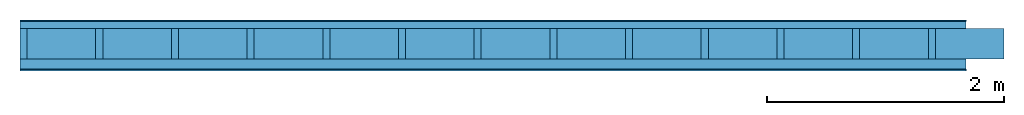
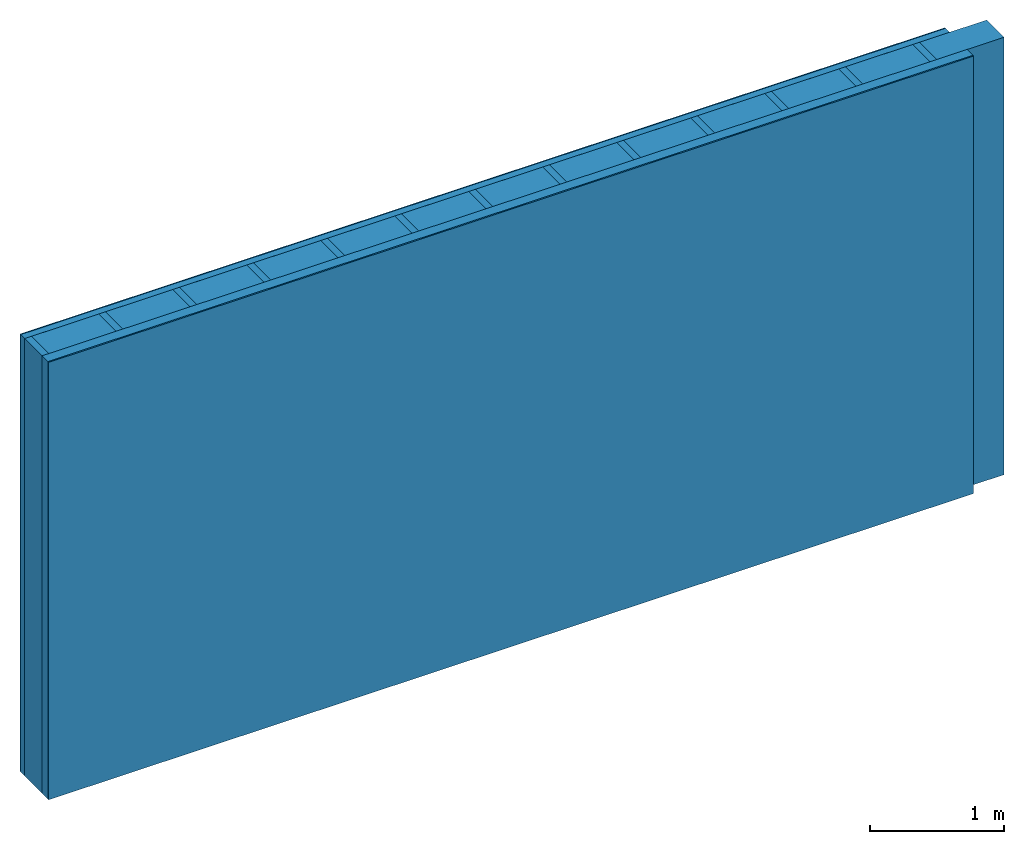
# One storey: 4 plates, 2 members, 1 element without a shape of its own.
"""IFC4 building model written with IfcOpenShell, lengths in metres."""

from ifc_helpers import new_model, si_unit, derived_unit, direction, frame, frame_2d, origin, origin_with_axes, place, context, project, spatial, rectangle, extrude, material, layer, layer_set, type_object, element, aggregate, save


model = new_model("IFC4")

# Units and contexts
plan_context = context("Plan", 3, precision=1e-05, world=origin(), true_north=direction((0.0, 1.0)))
model_context = context("Model", 3, precision=1e-05, world=origin(), true_north=direction((0.0, 1.0)))
ifc_project = project(units=[si_unit("LENGTHUNIT", "METRE"), derived_unit("SOUNDPRESSUREUNIT", [(si_unit("PRESSUREUNIT", "PASCAL", prefix="MICRO"), 0)]), si_unit("ENERGYUNIT", "JOULE", prefix="MEGA"), si_unit("MASSUNIT", "GRAM", prefix="KILO"), derived_unit("THERMALTRANSMITTANCEUNIT", [(si_unit("POWERUNIT", "WATT"), 1), (si_unit("AREAUNIT", "SQUARE_METRE"), -1), (si_unit("THERMODYNAMICTEMPERATUREUNIT", "KELVIN"), -1)]), derived_unit("AREADENSITYUNIT", [(si_unit("MASSUNIT", "GRAM", prefix="KILO"), 1), (si_unit("AREAUNIT", "SQUARE_METRE"), -1)]), derived_unit("USERDEFINED", [(si_unit("ENERGYUNIT", "JOULE", prefix="MEGA"), 1), (si_unit("AREAUNIT", "SQUARE_METRE"), -1)])], contexts=[plan_context, model_context])

# Site, building, storey
site = spatial("IfcSite", under=ifc_project)
building_placement = place(None, origin())
building = spatial("IfcBuilding", under=site, at=building_placement)
storey_placement = place(building_placement, origin())
storey = spatial("IfcBuildingStorey", under=building, at=storey_placement)

# Wall, members, plates
ifc_material_1 = material(Category="04.011")
ifc_layer_1 = layer(ifc_material_1, 0.01, Name="Surface 1")
ifc_material_2 = material(Category="10.009")
ifc_layer_2 = layer(ifc_material_2, 0.06, Name="outside 1st layer")
ifc_material_3 = material(Name="of the art")
ifc_layer_3 = layer(ifc_material_3, 0.0, Name="Bond")
ifc_layer_4 = layer(None, 0.26, Name="Support")
ifc_layer_5 = layer(ifc_material_3, 0.0, Name="Bond")
ifc_material_4 = material(Name="Solid timber panel")
ifc_layer_6 = layer(ifc_material_4, 0.087, Name="1st layer")
ifc_material_5 = material(Name="Plasterboard type A", Category="03.008")
ifc_layer_7 = layer(ifc_material_5, 0.0125, Name="Covering 1st layer")
ifc_material_6 = material(Name="joints", Category="04.017")
ifc_layer_8 = layer(ifc_material_6, 0.0, Name="Surface")
ifc_layer_set = layer_set([ifc_layer_1, ifc_layer_2, ifc_layer_3, ifc_layer_4, ifc_layer_5, ifc_layer_6, ifc_layer_7, ifc_layer_8])
wall_type = type_object("IfcWallType", Name="D0982", PredefinedType="NOTDEFINED", material=ifc_layer_set)
wall_placement = place(None, frame((0.0, 0.0, 0.0), z_axis=(0.0, -1.0, 0.0), x_axis=(1.0, 0.0, 0.0)))
wall = element("IfcWall", 1, at=wall_placement, inside=storey, type_object=wall_type, material=ifc_layer_set, Name="Wall #1")
ifc_material_7 = material()
member_1_placement = place(wall_placement, origin())
member_1 = element("IfcMember", 2, at=member_1_placement, material=ifc_material_7, Name="Support", context=plan_context, shape_type="SweptSolid", body=[
    extrude(rectangle(XDim=0.06, YDim=0.26, at=frame_2d((0.03, 0.13), x_axis=(1.0, 0.0))), frame((0.0, 4.0, 0.07), z_axis=(0.0, -1.0, 0.0), x_axis=(1.0, 0.0, 0.0)), (0.0, 0.0, 1.0), 4.0),
    extrude(rectangle(XDim=0.06, YDim=0.26, at=frame_2d((0.03, 0.13), x_axis=(1.0, 0.0))), frame((0.64, 4.0, 0.07), z_axis=(0.0, -1.0, 0.0), x_axis=(1.0, 0.0, 0.0)), (0.0, 0.0, 1.0), 4.0),
    extrude(rectangle(XDim=0.06, YDim=0.26, at=frame_2d((0.03, 0.13), x_axis=(1.0, 0.0))), frame((1.28, 4.0, 0.07), z_axis=(0.0, -1.0, 0.0), x_axis=(1.0, 0.0, 0.0)), (0.0, 0.0, 1.0), 4.0),
    extrude(rectangle(XDim=0.06, YDim=0.26, at=frame_2d((0.03, 0.13), x_axis=(1.0, 0.0))), frame((1.92, 4.0, 0.07), z_axis=(0.0, -1.0, 0.0), x_axis=(1.0, 0.0, 0.0)), (0.0, 0.0, 1.0), 4.0),
    extrude(rectangle(XDim=0.06, YDim=0.26, at=frame_2d((0.03, 0.13), x_axis=(1.0, 0.0))), frame((2.56, 4.0, 0.07), z_axis=(0.0, -1.0, 0.0), x_axis=(1.0, 0.0, 0.0)), (0.0, 0.0, 1.0), 4.0),
    extrude(rectangle(XDim=0.06, YDim=0.26, at=frame_2d((0.03, 0.13), x_axis=(1.0, 0.0))), frame((3.2, 4.0, 0.07), z_axis=(0.0, -1.0, 0.0), x_axis=(1.0, 0.0, 0.0)), (0.0, 0.0, 1.0), 4.0),
    extrude(rectangle(XDim=0.06, YDim=0.26, at=frame_2d((0.03, 0.13), x_axis=(1.0, 0.0))), frame((3.84, 4.0, 0.07), z_axis=(0.0, -1.0, 0.0), x_axis=(1.0, 0.0, 0.0)), (0.0, 0.0, 1.0), 4.0),
    extrude(rectangle(XDim=0.06, YDim=0.26, at=frame_2d((0.03, 0.13), x_axis=(1.0, 0.0))), frame((4.48, 4.0, 0.07), z_axis=(0.0, -1.0, 0.0), x_axis=(1.0, 0.0, 0.0)), (0.0, 0.0, 1.0), 4.0),
    extrude(rectangle(XDim=0.06, YDim=0.26, at=frame_2d((0.03, 0.13), x_axis=(1.0, 0.0))), frame((5.12, 4.0, 0.07), z_axis=(0.0, -1.0, 0.0), x_axis=(1.0, 0.0, 0.0)), (0.0, 0.0, 1.0), 4.0),
    extrude(rectangle(XDim=0.06, YDim=0.26, at=frame_2d((0.03, 0.13), x_axis=(1.0, 0.0))), frame((5.76, 4.0, 0.07), z_axis=(0.0, -1.0, 0.0), x_axis=(1.0, 0.0, 0.0)), (0.0, 0.0, 1.0), 4.0),
    extrude(rectangle(XDim=0.06, YDim=0.26, at=frame_2d((0.03, 0.13), x_axis=(1.0, 0.0))), frame((6.4, 4.0, 0.07), z_axis=(0.0, -1.0, 0.0), x_axis=(1.0, 0.0, 0.0)), (0.0, 0.0, 1.0), 4.0),
    extrude(rectangle(XDim=0.06, YDim=0.26, at=frame_2d((0.03, 0.13), x_axis=(1.0, 0.0))), frame((7.04, 4.0, 0.07), z_axis=(0.0, -1.0, 0.0), x_axis=(1.0, 0.0, 0.0)), (0.0, 0.0, 1.0), 4.0),
    extrude(rectangle(XDim=0.06, YDim=0.26, at=frame_2d((0.03, 0.13), x_axis=(1.0, 0.0))), frame((7.68, 4.0, 0.07), z_axis=(0.0, -1.0, 0.0), x_axis=(1.0, 0.0, 0.0)), (0.0, 0.0, 1.0), 4.0),
])
ifc_material_8 = material()
member_2_placement = place(wall_placement, origin())
member_2 = element("IfcMember", 3, at=member_2_placement, material=ifc_material_8, Name="Cavity", context=plan_context, shape_type="SweptSolid", body=[
    extrude(rectangle(XDim=0.58, YDim=0.26, at=frame_2d((0.29, 0.13), x_axis=(1.0, 0.0))), frame((0.06, 4.0, 0.07), z_axis=(0.0, -1.0, 0.0), x_axis=(1.0, 0.0, 0.0)), (0.0, 0.0, 1.0), 4.0),
    extrude(rectangle(XDim=0.58, YDim=0.26, at=frame_2d((0.29, 0.13), x_axis=(1.0, 0.0))), frame((0.7, 4.0, 0.07), z_axis=(0.0, -1.0, 0.0), x_axis=(1.0, 0.0, 0.0)), (0.0, 0.0, 1.0), 4.0),
    extrude(rectangle(XDim=0.58, YDim=0.26, at=frame_2d((0.29, 0.13), x_axis=(1.0, 0.0))), frame((1.34, 4.0, 0.07), z_axis=(0.0, -1.0, 0.0), x_axis=(1.0, 0.0, 0.0)), (0.0, 0.0, 1.0), 4.0),
    extrude(rectangle(XDim=0.58, YDim=0.26, at=frame_2d((0.29, 0.13), x_axis=(1.0, 0.0))), frame((1.98, 4.0, 0.07), z_axis=(0.0, -1.0, 0.0), x_axis=(1.0, 0.0, 0.0)), (0.0, 0.0, 1.0), 4.0),
    extrude(rectangle(XDim=0.58, YDim=0.26, at=frame_2d((0.29, 0.13), x_axis=(1.0, 0.0))), frame((2.62, 4.0, 0.07), z_axis=(0.0, -1.0, 0.0), x_axis=(1.0, 0.0, 0.0)), (0.0, 0.0, 1.0), 4.0),
    extrude(rectangle(XDim=0.58, YDim=0.26, at=frame_2d((0.29, 0.13), x_axis=(1.0, 0.0))), frame((3.26, 4.0, 0.07), z_axis=(0.0, -1.0, 0.0), x_axis=(1.0, 0.0, 0.0)), (0.0, 0.0, 1.0), 4.0),
    extrude(rectangle(XDim=0.58, YDim=0.26, at=frame_2d((0.29, 0.13), x_axis=(1.0, 0.0))), frame((3.9, 4.0, 0.07), z_axis=(0.0, -1.0, 0.0), x_axis=(1.0, 0.0, 0.0)), (0.0, 0.0, 1.0), 4.0),
    extrude(rectangle(XDim=0.58, YDim=0.26, at=frame_2d((0.29, 0.13), x_axis=(1.0, 0.0))), frame((4.54, 4.0, 0.07), z_axis=(0.0, -1.0, 0.0), x_axis=(1.0, 0.0, 0.0)), (0.0, 0.0, 1.0), 4.0),
    extrude(rectangle(XDim=0.58, YDim=0.26, at=frame_2d((0.29, 0.13), x_axis=(1.0, 0.0))), frame((5.18, 4.0, 0.07), z_axis=(0.0, -1.0, 0.0), x_axis=(1.0, 0.0, 0.0)), (0.0, 0.0, 1.0), 4.0),
    extrude(rectangle(XDim=0.58, YDim=0.26, at=frame_2d((0.29, 0.13), x_axis=(1.0, 0.0))), frame((5.82, 4.0, 0.07), z_axis=(0.0, -1.0, 0.0), x_axis=(1.0, 0.0, 0.0)), (0.0, 0.0, 1.0), 4.0),
    extrude(rectangle(XDim=0.58, YDim=0.26, at=frame_2d((0.29, 0.13), x_axis=(1.0, 0.0))), frame((6.46, 4.0, 0.07), z_axis=(0.0, -1.0, 0.0), x_axis=(1.0, 0.0, 0.0)), (0.0, 0.0, 1.0), 4.0),
    extrude(rectangle(XDim=0.58, YDim=0.26, at=frame_2d((0.29, 0.13), x_axis=(1.0, 0.0))), frame((7.1, 4.0, 0.07), z_axis=(0.0, -1.0, 0.0), x_axis=(1.0, 0.0, 0.0)), (0.0, 0.0, 1.0), 4.0),
    extrude(rectangle(XDim=0.58, YDim=0.26, at=frame_2d((0.29, 0.13), x_axis=(1.0, 0.0))), frame((7.74, 4.0, 0.07), z_axis=(0.0, -1.0, 0.0), x_axis=(1.0, 0.0, 0.0)), (0.0, 0.0, 1.0), 4.0),
])
plate_1_placement = place(wall_placement, origin())
plate_1 = element("IfcPlate", 4, at=plate_1_placement, material=ifc_material_1, Name="Surface 1", context=plan_context, shape_type="SweptSolid", body=[
    extrude(rectangle(XDim=8.0, YDim=4.0, at=frame_2d((4.0, 2.0), x_axis=(1.0, 0.0))), origin_with_axes(), (0.0, 0.0, 1.0), 0.01),
])
plate_2_placement = place(wall_placement, origin())
plate_2 = element("IfcPlate", 5, at=plate_2_placement, material=ifc_material_2, Name="outside 1st layer", context=plan_context, shape_type="SweptSolid", body=[
    extrude(rectangle(XDim=8.0, YDim=4.0, at=frame_2d((4.0, 2.0), x_axis=(1.0, 0.0))), frame((0.0, 0.0, 0.01), z_axis=(0.0, 0.0, 1.0), x_axis=(1.0, 0.0, 0.0)), (0.0, 0.0, 1.0), 0.06),
])
plate_3_placement = place(wall_placement, origin())
plate_3 = element("IfcPlate", 6, at=plate_3_placement, material=ifc_material_4, Name="1st layer", context=plan_context, shape_type="SweptSolid", body=[
    extrude(rectangle(XDim=8.0, YDim=4.0, at=frame_2d((4.0, 2.0), x_axis=(1.0, 0.0))), frame((0.0, 0.0, 0.33), z_axis=(0.0, 0.0, 1.0), x_axis=(1.0, 0.0, 0.0)), (0.0, 0.0, 1.0), 0.087),
])
plate_4_placement = place(wall_placement, origin())
plate_4 = element("IfcPlate", 7, at=plate_4_placement, material=ifc_material_5, Name="Covering 1st layer", context=plan_context, shape_type="SweptSolid", body=[
    extrude(rectangle(XDim=8.0, YDim=4.0, at=frame_2d((4.0, 2.0), x_axis=(1.0, 0.0))), frame((0.0, 0.0, 0.417), z_axis=(0.0, 0.0, 1.0), x_axis=(1.0, 0.0, 0.0)), (0.0, 0.0, 1.0), 0.0125),
])
aggregate(wall, [plate_1, plate_2, member_1, member_2, plate_3, plate_4])

save(model, "model.ifc")
